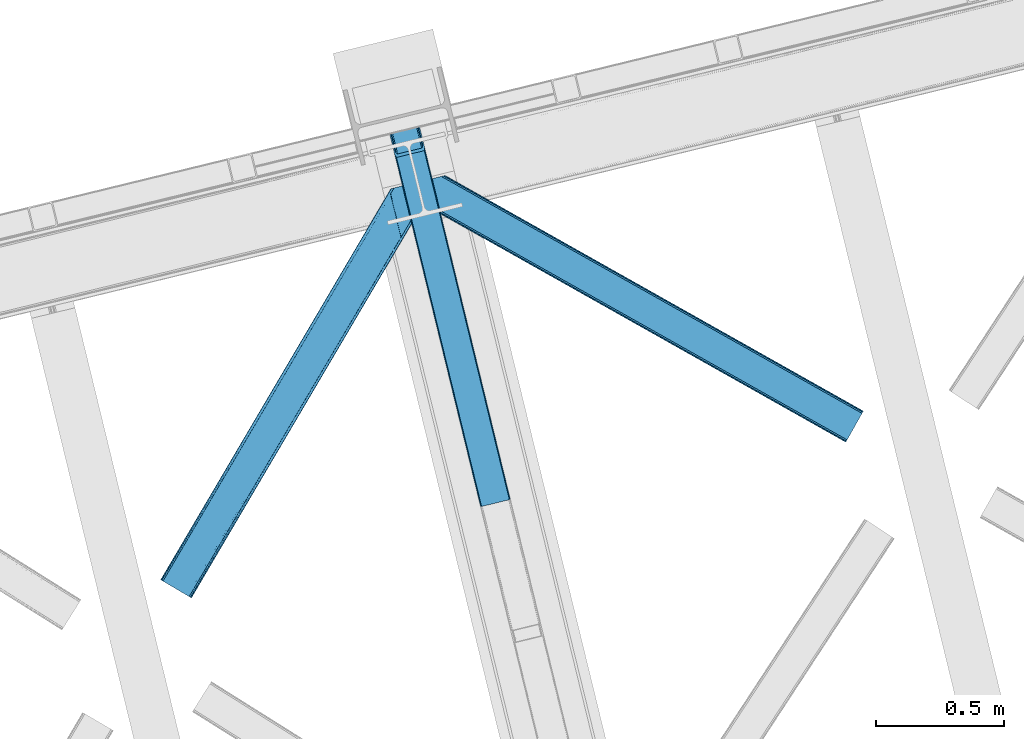
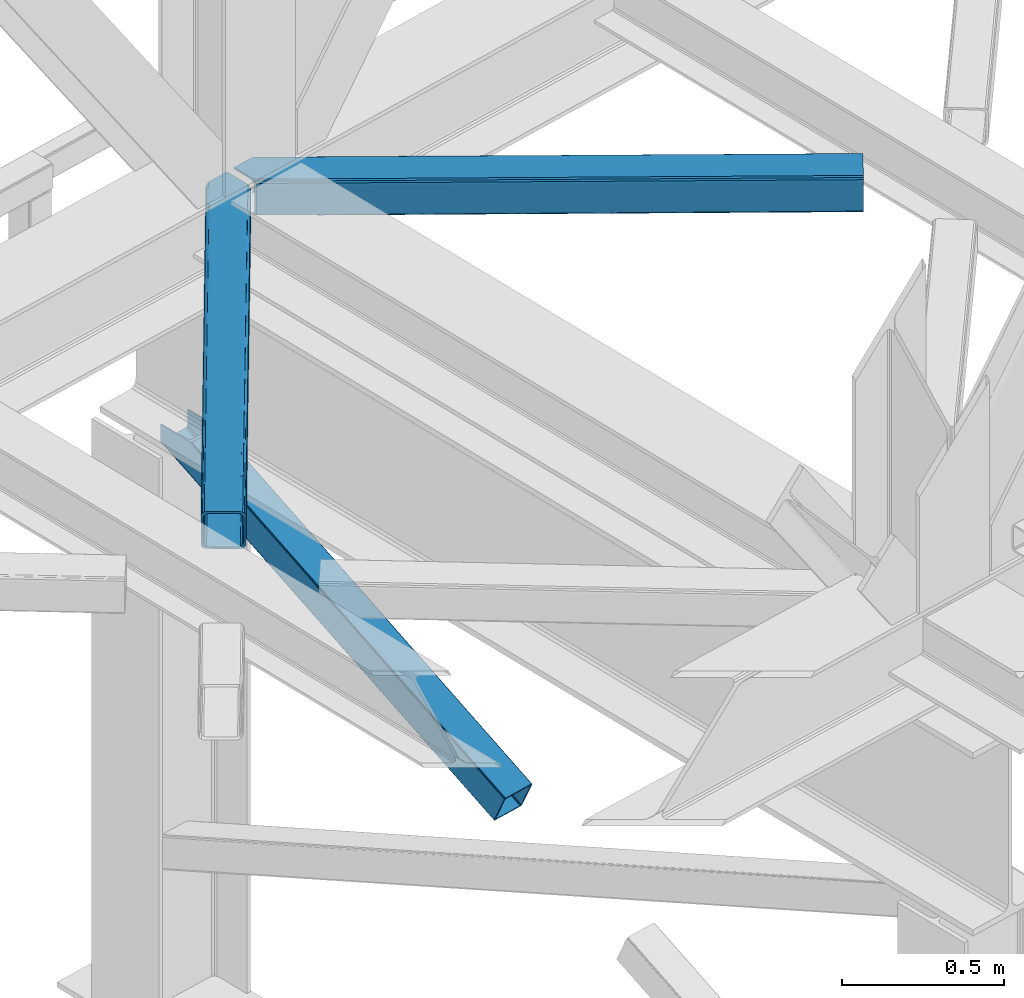
# One storey, part 40 of 92: 3 members.
"""IFC4 building model written with IfcOpenShell, lengths in millimetres."""

from ifc_helpers import new_model, entity, si_unit, converted_unit, derived_unit, direction, frame, origin, place, context, subcontext, project, spatial, triangles, type_object, element, save


model = new_model("IFC4")

# Units and contexts
model_context = context("Model", 3, precision=0.01, world=origin(), true_north=direction((6.12303176911189e-17, 1.0)))
plan_context = context("Plan", 3, precision=0.01, world=origin(), true_north=direction((6.12303176911189e-17, 1.0)))
body_context = subcontext(model_context, "Body", "Model", "MODEL_VIEW")
ifc_project = project(units=[si_unit("LENGTHUNIT", "METRE", prefix="MILLI"), si_unit("AREAUNIT", "SQUARE_METRE"), si_unit("VOLUMEUNIT", "CUBIC_METRE"), converted_unit("PLANEANGLEUNIT", "DEGREE", entity("IfcRatioMeasure", 0.0174532925199433), si_unit("PLANEANGLEUNIT", "RADIAN"), dimensions=[0, 0, 0, 0, 0, 0, 0]), si_unit("MASSUNIT", "GRAM", prefix="KILO"), derived_unit("MASSDENSITYUNIT", [(si_unit("MASSUNIT", "GRAM", prefix="KILO"), 1), (si_unit("LENGTHUNIT", "METRE"), -3)]), derived_unit("MOMENTOFINERTIAUNIT", [(si_unit("LENGTHUNIT", "METRE"), 4)]), si_unit("TIMEUNIT", "SECOND"), si_unit("FREQUENCYUNIT", "HERTZ"), si_unit("THERMODYNAMICTEMPERATUREUNIT", "DEGREE_CELSIUS"), derived_unit("THERMALTRANSMITTANCEUNIT", [(si_unit("MASSUNIT", "GRAM", prefix="KILO"), 1), (si_unit("THERMODYNAMICTEMPERATUREUNIT", "KELVIN"), -1), (si_unit("TIMEUNIT", "SECOND"), -3)]), derived_unit("VOLUMETRICFLOWRATEUNIT", [(si_unit("LENGTHUNIT", "METRE"), 3), (si_unit("TIMEUNIT", "SECOND"), -1)]), derived_unit("MASSFLOWRATEUNIT", [(si_unit("MASSUNIT", "GRAM", prefix="KILO"), 1), (si_unit("TIMEUNIT", "SECOND"), -1)]), derived_unit("ROTATIONALFREQUENCYUNIT", [(si_unit("TIMEUNIT", "SECOND"), -1)]), si_unit("ELECTRICCURRENTUNIT", "AMPERE"), si_unit("ELECTRICVOLTAGEUNIT", "VOLT"), si_unit("POWERUNIT", "WATT"), si_unit("FORCEUNIT", "NEWTON", prefix="KILO"), si_unit("ILLUMINANCEUNIT", "LUX"), si_unit("LUMINOUSFLUXUNIT", "LUMEN"), si_unit("LUMINOUSINTENSITYUNIT", "CANDELA"), derived_unit("USERDEFINED", [(si_unit("MASSUNIT", "GRAM", prefix="KILO"), -1), (si_unit("LENGTHUNIT", "METRE"), -2), (si_unit("TIMEUNIT", "SECOND"), 3), (si_unit("LUMINOUSFLUXUNIT", "LUMEN"), 1)]), derived_unit("LINEARVELOCITYUNIT", [(si_unit("LENGTHUNIT", "METRE"), 1), (si_unit("TIMEUNIT", "SECOND"), -1)]), si_unit("PRESSUREUNIT", "PASCAL"), derived_unit("USERDEFINED", [(si_unit("LENGTHUNIT", "METRE"), -2), (si_unit("MASSUNIT", "GRAM", prefix="KILO"), 1), (si_unit("TIMEUNIT", "SECOND"), -2)]), derived_unit("LINEARFORCEUNIT", [(si_unit("MASSUNIT", "GRAM", prefix="KILO"), 1), (si_unit("LENGTHUNIT", "METRE"), 1), (si_unit("TIMEUNIT", "SECOND"), -2), (si_unit("LENGTHUNIT", "METRE"), -1)]), derived_unit("PLANARFORCEUNIT", [(si_unit("MASSUNIT", "GRAM", prefix="KILO"), 1), (si_unit("LENGTHUNIT", "METRE"), 1), (si_unit("TIMEUNIT", "SECOND"), -2), (si_unit("LENGTHUNIT", "METRE"), -2)])], contexts=[model_context, plan_context])

# Site, building, storey
site_placement = place(None, origin())
site = spatial("IfcSite", under=ifc_project, at=site_placement, CompositionType="ELEMENT")
building_placement = place(site_placement, origin())
building = spatial("IfcBuilding", under=site, at=building_placement, CompositionType="ELEMENT")
storey_placement = place(building_placement, frame((0.0, 0.0, 15900.0)))
storey = spatial("IfcBuildingStorey", under=building, at=storey_placement, Name="05", CompositionType="ELEMENT", Elevation=15900.0)

# Members
member_type_1 = type_object("IfcMemberType", PredefinedType="BRACE")
member_1_placement = place(storey_placement, frame((-49464.95, 7483.37, 1850.35)))
element("IfcMember", 1, at=member_1_placement, inside=storey, type_object=member_type_1, ObjectType="Steel Vertical Brace", PredefinedType="BRACE", context=body_context, shape_type="Tessellation", body=[
    triangles([(109.783996582031, 1519.24680175781, 671.707836914062), (462.204345703125, 73.4908630371092, 0.0), (359.21993408203, 48.3871627807621, 0.0), (6.79958496093604, 1494.14310150146, 671.707836914062), (464.855346679688, 73.9117675781254, 0.48601684570167), (467.213342285155, 73.843167114258, 1.86965332031104), (112.188500976561, 1519.8328125, 672.832186889649), (468.906262207034, 73.2949447631836, 3.93929443359229), (114.593005371091, 1520.41940460205, 673.956536865233), (469.682958984376, 72.3502349853516, 6.38100585937354), (115.588293457033, 1520.66183166504, 676.672650146484), (116.583581542967, 1520.90484008789, 679.387600708007), (353.099377441409, 43.9310394287113, 6.38100585937354), (0.0, 1492.48564453125, 679.387600708007), (0.99528808593459, 1492.72807159424, 676.672650146484), (353.355175781253, 45.128059387207, 3.93929443359229), (1.99057617187646, 1492.97108001709, 673.956536865233), (354.606262207031, 46.3954238891602, 1.86965332031104), (4.39508056640625, 1493.55767211914, 672.832186889649), (356.666601562501, 47.5395401000978, 0.48601684570167), (144.93533935547, 1404.59159088135, 741.646591186523), (116.583581542967, 1520.90484008789, 741.646591186523), (480.012561035153, 29.9807281494141, 102.993713378906), (28.3517578125029, 1376.17239532471, 741.646591186523), (0.0, 1492.48564453125, 741.646591186523), (363.428979492186, 1.5615325927738, 102.993713378906), (476.445336914061, 26.3722274780275, 108.888702392578), (144.460949707034, 1388.29607391357, 741.646591186523), (142.168066406251, 1386.40316619873, 741.646591186523), (473.896655273435, 25.5251861572269, 109.37471923828), (478.505676269531, 27.5169250488279, 107.505065917969), (145.795751953126, 1392.41733398437, 741.646591186523), (479.75676269531, 28.7837081909183, 105.435424804688), (145.963183593747, 1398.13907775879, 741.646591186523), (39.1790039062471, 1361.29946594238, 741.646591186523), (370.907592773438, 0.421485900878906, 109.37471923828), (364.205676269528, 0.61682281494177, 105.435424804688), (30.4120971679658, 1369.97219238281, 741.646591186523), (365.90324707031, 0.0686004638673694, 107.505065917969), (33.1933227539048, 1364.96900939941, 741.646591186523), (368.256591796875, 0.0, 108.888702392578), (36.2722045898408, 1361.92384643555, 741.646591186523), (138.056689453122, 1403.03994140625, 741.646591186523), (137.200927734375, 1415.21477966309, 741.646591186523), (111.728063964845, 1519.72061004639, 741.646591186523), (138.22412109375, 1408.76284790039, 741.646591186523), (136.726538085939, 1398.91926269531, 741.646591186523), (134.429003906247, 1397.02635498047, 741.646591186523), (35.169946289061, 1377.96065826416, 741.646591186523), (32.3887207031221, 1382.96384124756, 741.646591186523), (30.333032226561, 1389.16346282959, 741.646591186523), (4.85551757812209, 1493.66987457275, 741.646591186523), (38.2534790039063, 1374.91549530029, 741.646591186523), (41.1602783203125, 1374.29111480713, 741.646591186523), (474.668701171875, 30.7952133178715, 98.4370147705085), (474.412902832031, 29.5981933593748, 100.87872619629), (473.157165527344, 28.3308288574217, 102.948367309571), (471.101477050783, 27.186712646484, 104.330841064453), (468.548144531247, 26.3390899658207, 104.816857910155), (375.279418945313, 3.60384979248011, 104.816857910155), (372.62841796875, 3.18294525146484, 104.330841064453), (370.270422363283, 3.25154571533221, 102.948367309571), (368.577502441403, 3.79976806640661, 100.87872619629), (367.796154785159, 4.74447784423865, 98.4370147705085), (111.728063964845, 1519.72061004639, 684.873312377931), (465.315783691403, 69.1678710937504, 10.9377044677749), (4.85551757812209, 1493.66987457275, 684.873312377931), (358.443237304688, 43.1165542602539, 10.9377044677749), (462.84151611328, 70.6602218627932, 6.42635192871239), (464.534436035159, 70.1125808715824, 8.49599304199364), (460.483520507813, 70.7294036865233, 5.04387817382667), (457.83251953125, 70.3079177856443, 4.557861328125), (359.954772949219, 45.5809387207028, 6.42635192871239), (362.01046142578, 46.7256362915041, 5.04387817382667), (358.699035644531, 44.3135742187496, 8.49599304199364), (364.563793945315, 47.5726776123047, 4.557861328125), (11.6551025390654, 1495.32733154297, 677.193548583986), (9.25059814452834, 1494.74132080078, 678.31789855957), (6.84609374999854, 1494.15531005859, 679.443411254884), (104.923828125, 1518.06257171631, 677.193548583986), (107.332983398439, 1518.64916381836, 678.31789855957), (109.73283691406, 1519.23517456055, 679.443411254884), (5.85080566406396, 1493.91288299561, 682.158361816408), (110.732775878903, 1519.47760162354, 682.158361816408)], [[1, 2, 3], [3, 4, 1], [5, 2, 1], [6, 5, 7], [8, 6, 9], [10, 8, 11], [11, 12, 10], [9, 11, 8], [7, 9, 6], [1, 7, 5], [13, 14, 15], [16, 15, 17], [18, 17, 19], [20, 19, 4], [4, 3, 20], [19, 20, 18], [17, 18, 16], [15, 16, 13], [12, 21, 10], [21, 12, 22], [23, 10, 21], [24, 14, 13], [24, 25, 14], [13, 26, 24], [27, 28, 29], [29, 30, 27], [31, 32, 28], [28, 27, 31], [33, 34, 32], [32, 31, 33], [23, 21, 34], [34, 33, 23], [30, 29, 35], [35, 36, 30], [37, 38, 26], [24, 26, 38], [39, 40, 37], [38, 37, 40], [41, 42, 39], [40, 39, 42], [36, 35, 41], [42, 41, 35], [43, 34, 21], [22, 44, 21], [44, 22, 45], [44, 46, 21], [46, 43, 21], [47, 34, 43], [32, 29, 28], [32, 34, 47], [32, 48, 29], [29, 48, 35], [47, 48, 32], [24, 38, 49], [49, 50, 24], [50, 51, 24], [51, 25, 24], [52, 25, 51], [38, 53, 49], [54, 40, 35], [54, 35, 48], [54, 53, 40], [35, 40, 42], [53, 38, 40], [44, 55, 46], [56, 46, 55], [46, 56, 43], [57, 43, 56], [43, 57, 47], [58, 47, 57], [47, 58, 48], [59, 48, 58], [48, 59, 54], [60, 54, 59], [54, 60, 61], [61, 53, 54], [53, 61, 62], [62, 49, 53], [49, 62, 63], [63, 50, 49], [50, 63, 64], [64, 51, 50], [44, 65, 66], [44, 45, 65], [66, 55, 44], [67, 51, 68], [51, 67, 52], [64, 68, 51], [55, 23, 56], [57, 33, 31], [31, 27, 57], [23, 55, 10], [23, 33, 57], [57, 56, 23], [59, 30, 36], [30, 58, 57], [59, 58, 30], [30, 57, 27], [6, 69, 5], [66, 10, 55], [69, 8, 10], [70, 10, 66], [8, 69, 6], [69, 2, 5], [10, 70, 69], [69, 71, 2], [2, 72, 3], [72, 2, 71], [62, 26, 63], [36, 60, 59], [61, 36, 62], [36, 61, 60], [62, 36, 41], [64, 63, 26], [41, 39, 62], [37, 62, 39], [64, 26, 13], [37, 26, 62], [73, 20, 3], [74, 73, 3], [75, 13, 73], [76, 3, 72], [3, 76, 74], [18, 20, 73], [13, 68, 64], [16, 73, 13], [68, 13, 75], [73, 16, 18], [77, 1, 4], [4, 19, 78], [19, 17, 15], [19, 79, 78], [4, 78, 77], [79, 19, 15], [80, 1, 77], [9, 7, 11], [7, 1, 81], [81, 82, 7], [7, 82, 11], [80, 81, 1], [11, 82, 12], [83, 14, 67], [15, 14, 79], [83, 79, 14], [25, 67, 14], [25, 52, 67], [12, 84, 65], [84, 12, 82], [65, 22, 12], [22, 65, 45], [72, 80, 76], [77, 76, 80], [66, 65, 84], [70, 84, 82], [69, 82, 81], [71, 81, 80], [80, 72, 71], [81, 71, 69], [82, 69, 70], [84, 70, 66], [74, 76, 77], [73, 74, 78], [75, 73, 79], [68, 75, 83], [83, 67, 68], [79, 83, 75], [78, 79, 73], [77, 78, 74]]),
])
member_type_2 = type_object("IfcMemberType", PredefinedType="BRACE")
member_2_placement = place(storey_placement, frame((-49332.88, 7733.55, 3511.0)))
element("IfcMember", 2, at=member_2_placement, inside=storey, type_object=member_type_2, ObjectType="Steel Horizontal Brace", PredefinedType="BRACE", context=body_context, shape_type="Tessellation", body=[
    triangles([(1656.08961181641, 0.0, 122.500662231447), (1656.74538574219, 1.16039428710974, 129.197927856447), (23.8915649414048, 919.17296447754, 122.500662231447), (23.4590332031294, 920.94494934082, 129.197927856447), (1658.60573730469, 4.46600646972638, 134.874325561526), (22.2265502929731, 925.991734313965, 134.874325561526), (1661.39161376953, 9.41279754638708, 138.667117309571), (20.3894531250044, 933.544180297852, 138.667117309571), (1664.67513427734, 15.2484878540045, 139.999594116212), (18.2174926757798, 942.452938842774, 139.999594116212), (1656.08961181641, 0.0, 17.5000946044929), (23.8915649414048, 919.17296447754, 17.5000946044929), (1716.19757080078, 106.738252258301, 139.999594116212), (69.4469238281235, 1034.10722808838, 139.999594116212), (0.0, 1017.17919158936, 139.999594116212), (1719.4857421875, 112.573361206055, 138.667117309571), (78.971923828125, 1036.42917938232, 138.667117309571), (1722.27161865235, 117.520152282715, 134.874325561526), (87.0458496093779, 1038.39766387939, 134.874325561526), (1724.13197021485, 120.825764465332, 129.197927856447), (92.4408691406279, 1039.71269989014, 129.197927856447), (1724.78774414062, 121.986740112305, 122.500662231447), (94.3384277343794, 1040.17488098145, 122.500662231447), (1724.78774414062, 121.986740112305, 17.5000946044929), (94.3384277343794, 1040.17488098145, 17.5000946044929), (1656.74538574219, 1.16039428710974, 10.8028289794929), (1658.60573730469, 4.46600646972638, 5.12526855468968), (196.057800292969, 824.821165466309, 8.8831787109375), (196.076403808598, 825.066499328613, 8.50064392089917), (23.3706665039063, 921.307136535645, 10.8691040039084), (195.062512207034, 824.99848022461, 9.50058288574292), (195.732238769531, 824.878720092774, 9.08316650390771), (23.263696289061, 921.747807312012, 9.50058288574292), (195.220642089844, 828.57035522461, 5.12526855468968), (1664.67513427734, 15.2484878540045, 0.0), (1661.39161376953, 9.41279754638708, 1.33247680664135), (193.378894042973, 836.122801208497, 1.33247680664135), (191.206933593749, 845.031559753418, 0.0), (1716.19757080078, 106.738252258301, 0.0), (157.162499999999, 984.71082458496, 0.0), (191.346459960936, 843.22294921875, 9.20757751465135), (191.290649414063, 844.06824645996, 8.85411071777344), (191.104614257813, 845.460603332519, 8.41343994140698), (18.8686157226548, 939.774032592774, 9.50058288574292), (1724.13197021485, 120.825764465332, 10.8028289794929), (92.0548461914077, 1039.61851959229, 10.8702667236357), (150.921020507813, 1006.08800811768, 9.50058288574292), (1722.27161865235, 117.520152282715, 5.12526855468968), (153.148791503911, 1001.17202911377, 5.12526855468968), (152.293029785156, 1004.67588500977, 8.50064392089917), (151.60469970703, 1005.38223724365, 9.00061340332104), (91.5851074218735, 1039.50341033936, 9.50058288574292), (1719.4857421875, 112.573361206055, 1.33247680664135), (154.990539550781, 993.619583129884, 1.33247680664135), (156.250927734378, 986.702563476562, 9.11688537597729), (155.813745117186, 987.634483337403, 9.42384338378906), (156.692761230472, 985.76134185791, 8.80760192871094), (157.129943847656, 984.828840637208, 8.50064392089917), (155.316101074219, 988.061782836915, 9.50058288574292), (72.3118652343765, 1034.80544128418, 9.50058288574292), (159.43212890625, 975.399183654786, 6.99957275390625), (188.937304687504, 854.343782043456, 6.99957275390625), (1668.11213378907, 21.3475341796875, 6.99957275390625), (1712.76522216797, 100.639205932617, 6.99957275390625), (19.9569213867217, 935.303375244142, 12.1260040283232), (1662.0380859375, 10.5650527954103, 12.1260040283232), (1664.82396240235, 15.5124252319338, 8.3320495605476), (1659.52661132813, 6.09904632568396, 24.4996673583992), (1660.177734375, 7.26002197265643, 17.8035644531265), (21.6219360351606, 928.485186767578, 24.4996673583992), (21.1894042968779, 930.25717163086, 17.8035644531265), (1716.04874267578, 106.474314880371, 8.3320495605476), (1718.83927001953, 111.421105957032, 12.1260040283232), (77.0929687500029, 1035.9704864502, 12.1260040283232), (1720.69962158203, 114.726718139648, 17.8035644531265), (82.4879882812529, 1037.2861038208, 17.8035644531265), (1721.35074462891, 115.887112426758, 24.4996673583992), (84.3808959960952, 1037.74770355225, 24.4996673583992), (1659.52661132813, 6.09904632568396, 115.501089477541), (21.6219360351606, 928.485186767578, 115.501089477541), (21.1894042968779, 930.25717163086, 122.196029663086), (19.9569213867217, 935.303375244142, 127.87475280762), (15.9478637695356, 951.765161132812, 133.000021362306), (18.1198242187529, 942.855821228027, 131.667544555665), (0.0, 1017.17919158936, 133.000021362306), (1668.11213378907, 21.3475341796875, 133.000021362306), (1664.82396240235, 15.5124252319338, 131.667544555665), (1662.0380859375, 10.5650527954103, 127.87475280762), (1660.177734375, 7.26002197265643, 122.196029663086), (1718.83927001953, 111.421105957032, 127.87475280762), (1720.69962158203, 114.726718139648, 122.196029663086), (1721.35074462891, 115.887112426758, 115.501089477541), (1712.76522216797, 100.639205932617, 133.000021362306), (1716.04874267578, 106.474314880371, 131.667544555665), (77.0929687500029, 1035.9704864502, 127.87475280762), (69.0143920898481, 1034.00200195312, 131.667544555665), (82.4879882812529, 1037.2861038208, 122.196029663086), (59.4893920898467, 1031.68005065918, 133.000021362306), (84.3808959960952, 1037.74770355225, 115.501089477541)], [[1, 2, 3], [4, 3, 2], [2, 5, 4], [6, 4, 5], [5, 7, 6], [8, 6, 7], [7, 9, 8], [10, 8, 9], [11, 1, 12], [3, 12, 1], [13, 10, 9], [10, 13, 14], [15, 10, 14], [13, 16, 17], [17, 14, 13], [16, 18, 19], [19, 17, 16], [18, 20, 21], [21, 19, 18], [20, 22, 23], [23, 21, 20], [22, 24, 23], [25, 23, 24], [26, 11, 12], [27, 28, 29], [26, 30, 31], [31, 27, 26], [31, 32, 27], [30, 33, 31], [29, 34, 27], [35, 36, 37], [37, 38, 35], [36, 27, 34], [34, 37, 36], [12, 30, 26], [39, 35, 38], [38, 40, 39], [41, 42, 29], [42, 43, 29], [41, 31, 33], [33, 44, 41], [45, 46, 25], [46, 45, 47], [45, 48, 49], [49, 50, 45], [45, 50, 51], [51, 47, 45], [47, 52, 46], [48, 53, 54], [54, 49, 48], [53, 39, 40], [40, 54, 53], [25, 24, 45], [51, 55, 56], [50, 57, 55], [50, 58, 57], [47, 59, 52], [60, 52, 59], [61, 40, 62], [54, 58, 49], [58, 54, 40], [49, 58, 50], [40, 61, 58], [62, 40, 38], [37, 43, 38], [43, 37, 34], [38, 43, 62], [34, 29, 43], [63, 64, 62], [61, 62, 64], [63, 62, 43], [41, 65, 66], [41, 44, 65], [43, 66, 67], [66, 43, 42], [42, 41, 66], [43, 67, 63], [68, 69, 70], [71, 70, 69], [69, 66, 71], [65, 71, 66], [72, 58, 61], [57, 72, 55], [57, 58, 72], [56, 55, 72], [73, 74, 59], [59, 72, 73], [74, 60, 59], [73, 75, 76], [76, 74, 73], [75, 77, 78], [78, 76, 75], [61, 64, 72], [79, 68, 80], [70, 80, 68], [81, 6, 82], [80, 70, 3], [4, 81, 3], [81, 4, 6], [81, 80, 3], [70, 12, 3], [71, 65, 33], [33, 30, 71], [30, 12, 71], [70, 71, 12], [83, 10, 15], [10, 84, 8], [84, 10, 83], [15, 85, 83], [84, 82, 8], [44, 33, 65], [8, 82, 6], [86, 87, 84], [84, 83, 86], [87, 88, 82], [82, 84, 87], [88, 89, 81], [81, 82, 88], [89, 79, 80], [80, 81, 89], [20, 90, 91], [92, 24, 22], [20, 91, 22], [20, 18, 90], [91, 92, 22], [90, 18, 16], [93, 13, 9], [13, 94, 16], [94, 13, 93], [94, 90, 16], [45, 73, 48], [77, 24, 92], [24, 75, 45], [75, 24, 77], [45, 75, 73], [39, 64, 35], [53, 48, 73], [73, 72, 53], [72, 64, 39], [39, 53, 72], [88, 7, 5], [9, 86, 93], [9, 87, 86], [87, 9, 7], [88, 87, 7], [79, 1, 11], [2, 89, 88], [5, 2, 88], [89, 2, 1], [79, 89, 1], [36, 66, 27], [35, 64, 63], [63, 67, 35], [67, 66, 36], [36, 35, 67], [26, 27, 66], [11, 68, 79], [69, 11, 26], [11, 69, 68], [69, 26, 66], [95, 96, 17], [19, 95, 17], [19, 21, 97], [95, 19, 97], [97, 21, 23], [96, 14, 17], [15, 98, 85], [15, 14, 98], [96, 98, 14], [97, 23, 99], [78, 25, 76], [23, 78, 99], [25, 46, 76], [23, 25, 78], [52, 76, 46], [74, 76, 52], [60, 74, 52], [93, 83, 98], [93, 86, 83], [83, 85, 98], [77, 92, 99], [99, 78, 77], [92, 91, 99], [97, 99, 91], [91, 90, 97], [95, 97, 90], [90, 94, 95], [96, 95, 94], [94, 93, 96], [98, 96, 93]]),
])
member_type_3 = type_object("IfcMemberType", PredefinedType="BRACE")
member_3_placement = place(storey_placement, frame((-50348.28, 7126.42, 3511.0)))
element("IfcMember", 3, at=member_3_placement, inside=storey, type_object=member_type_3, ObjectType="Steel Horizontal Brace", PredefinedType="BRACE", context=body_context, shape_type="Tessellation", body=[
    triangles([(105.565649414064, 8.87852783203198, 0.0), (15.0828002929702, 62.1485321044929, 0.0), (892.847827148435, 1346.13992614746, 0.0), (857.170935058595, 1492.50308532715, 0.0), (854.896655273435, 1501.83798065186, 1.33247680664135), (9.31105957031104, 65.5459991455082, 1.33247680664135), (852.966540527341, 1509.7520324707, 5.12526855468968), (4.4183349609375, 68.4266372680668, 5.12526855468968), (851.678247070311, 1515.03950042725, 10.8028289794929), (1.14876708984229, 70.3509384155277, 10.8028289794929), (851.222460937497, 1516.89636383057, 17.5000946044929), (0.0, 71.027059936524, 17.5000946044929), (893.638476562497, 1342.89826354981, 0.155804443362285), (111.337390136716, 5.48106079101581, 1.33247680664135), (899.559045410155, 1344.34178009033, 1.33247680664135), (912.390820312496, 1347.47007751465, 10.8028289794929), (914.195361328122, 1347.90958557129, 17.5000946044929), (120.643798828125, 0.0, 17.5000946044929), (119.499682617185, 0.676121520996276, 10.8028289794929), (907.251599121089, 1346.21724700928, 5.12526855468968), (116.230114746089, 2.60042266845721, 5.12526855468968), (902.498400878903, 1345.05743408203, 17.9802978515654), (893.638476562497, 1342.89826354981, 9.69243164062573), (897.768457031249, 1343.90517883301, 12.1260040283232), (903.726232910158, 1345.35683441162, 19.4999725341804), (914.195361328122, 1347.90958557129, 19.4999725341804), (1011.61732177734, 1513.38669433594, 19.4999725341804), (1008.98957519531, 1524.16103668213, 19.4999725341804), (1011.61732177734, 1513.38669433594, 122.500662231447), (120.643798828125, 0.0, 122.500662231447), (114.61160888672, 3.5515274047857, 24.4996673583992), (1009.24072265625, 1523.14423828125, 24.4996673583992), (113.462841796871, 4.22706756591833, 17.8035644531265), (110.197924804685, 6.15195007324292, 12.1260040283232), (105.305200195311, 9.03200683593786, 8.3320495605476), (99.5334594726519, 12.4294738769531, 6.99957275390625), (892.685046386716, 1346.80035095215, 8.88434143066479), (890.471228027345, 1355.89747009277, 6.99957275390625), (21.114990234375, 58.5975860595709, 6.99957275390625), (859.547534179685, 1482.74496002197, 6.99957275390625), (853.961828613283, 1505.66042175293, 18.5000335693367), (851.222460937497, 1516.89636383057, 18.5000335693367), (854.096704101561, 1505.10929260254, 17.8803039550803), (855.343139648438, 1499.99448852539, 12.1260040283232), (857.273254394531, 1492.08043670654, 8.3320495605476), (1009.24072265625, 1523.14423828125, 115.501089477541), (114.61160888672, 3.5515274047857, 115.501089477541), (1008.78493652344, 1525.00110168457, 122.196029663086), (113.462841796871, 4.22706756591833, 122.196029663086), (1007.49664306641, 1530.28915100098, 127.87475280762), (110.197924804685, 6.15195007324292, 127.87475280762), (1005.57117919921, 1538.20320281983, 131.667544555665), (105.305200195311, 9.03200683593786, 131.667544555665), (1003.29224853515, 1547.53809814453, 133.000021362306), (99.5334594726519, 12.4294738769531, 133.000021362306), (851.952648925777, 1518.13291625977, 19.4999725341804), (854.580395507808, 1507.35857391358, 19.4999725341804), (851.780566406247, 1517.84049224854, 19.2639404296897), (854.43156738281, 1506.95045928955, 19.2592895507842), (851.589880371095, 1517.5149307251, 19.0000030517585), (854.268786621091, 1506.50978851318, 19.0000030517585), (851.394543457027, 1517.1887878418, 18.736065673831), (854.110656738281, 1506.06853637695, 18.7407165527366), (908.014343261719, 1598.12687072754, 19.4999725341804), (897.545214843747, 1595.57411956787, 19.4999725341804), (1011.16618652343, 1515.24355773926, 129.197927856447), (1009.8778930664, 1520.53160705566, 134.874325561526), (1008.43146972656, 1526.45624542236, 137.999716186525), (986.311889648438, 1617.21175231934, 137.999716186525), (986.311889648438, 1617.21175231934, 133.000021362306), (897.545214843747, 1595.57411956787, 122.500662231447), (0.0, 71.027059936524, 122.500662231447), (7.18095703124709, 66.7999923706057, 17.8035644531265), (10.4505249023423, 64.875109863282, 12.1260040283232), (6.03218994140479, 67.4755325317383, 24.4996673583992), (907.028356933595, 1597.88560638428, 24.4996673583992), (15.3432495117158, 61.9950531005861, 8.3320495605476), (908.832897949214, 1598.32569580078, 122.196029663086), (899.349755859374, 1596.01362762451, 129.197927856447), (904.48897705078, 1597.26645812988, 134.874325561526), (930.738537597652, 1603.66548614502, 133.000021362306), (910.246765136719, 1598.67044219971, 137.999716186525), (921.664672851563, 1601.45341186523, 131.667544555665), (913.972119140621, 1599.57852630615, 127.87475280762), (907.028356933595, 1597.88560638428, 115.501089477541), (21.114990234375, 58.5975860595709, 133.000021362306), (6.03218994140479, 67.4755325317383, 115.501089477541), (15.3432495117158, 61.9950531005861, 131.667544555665), (10.4505249023423, 64.875109863282, 127.87475280762), (7.18095703124709, 66.7999923706057, 122.196029663086), (119.499682617185, 0.676121520996276, 129.197927856447), (116.230114746089, 2.60042266845721, 134.874325561526), (111.337390136716, 5.48106079101581, 138.667117309571), (105.565649414064, 8.87852783203198, 139.999594116212), (15.0828002929702, 62.1485321044929, 139.999594116212), (9.31105957031104, 65.5459991455082, 138.667117309571), (4.4183349609375, 68.4266372680668, 134.874325561526), (1.14876708984229, 70.3509384155277, 129.197927856447), (896.991760253906, 1576.15611877441, 137.999716186525), (938.18924560547, 1407.14434204102, 137.999716186525), (899.024194335936, 1563.59525756836, 139.999594116212), (897.042919921871, 1571.7232498169, 138.999655151369), (896.801074218747, 1573.1371170044, 138.639212036134), (896.926647949214, 1575.15443572998, 138.211331176761), (896.86153564453, 1574.14170684815, 138.427597045898), (937.477661132813, 1407.08620605469, 138.29272155762), (937.082336425781, 1408.09544677734, 138.646188354494), (936.682360839841, 1409.1046875, 138.999655151369), (934.701086425783, 1417.23267974854, 139.999594116212)], [[1, 2, 3], [4, 3, 2], [5, 4, 6], [2, 6, 4], [7, 5, 8], [6, 8, 5], [9, 7, 10], [8, 10, 7], [11, 9, 12], [10, 12, 9], [1, 3, 13], [13, 14, 1], [13, 15, 14], [16, 17, 18], [18, 19, 16], [20, 16, 19], [19, 21, 20], [15, 20, 21], [21, 14, 15], [20, 22, 16], [23, 24, 15], [23, 15, 13], [15, 24, 20], [16, 25, 17], [20, 24, 22], [16, 22, 25], [26, 17, 25], [26, 25, 27], [28, 27, 25], [27, 29, 26], [30, 26, 29], [26, 18, 17], [30, 18, 26], [31, 32, 25], [25, 33, 31], [25, 22, 33], [32, 28, 25], [33, 22, 24], [34, 24, 23], [23, 35, 34], [36, 35, 37], [37, 38, 36], [23, 37, 35], [24, 34, 33], [39, 36, 38], [38, 40, 39], [9, 11, 41], [11, 42, 41], [43, 9, 41], [43, 7, 9], [44, 7, 43], [5, 44, 45], [44, 5, 7], [4, 5, 45], [45, 40, 4], [37, 23, 13], [37, 3, 38], [3, 40, 38], [40, 3, 4], [37, 13, 3], [46, 32, 31], [31, 47, 46], [48, 46, 49], [47, 49, 46], [50, 48, 51], [49, 51, 48], [52, 50, 53], [51, 53, 50], [54, 52, 55], [53, 55, 52], [56, 57, 58], [59, 58, 57], [58, 59, 60], [61, 60, 59], [60, 61, 62], [63, 62, 61], [62, 63, 42], [41, 42, 63], [57, 56, 64], [65, 64, 56], [66, 48, 67], [46, 29, 27], [27, 32, 46], [32, 27, 28], [48, 29, 46], [66, 29, 48], [50, 68, 67], [52, 68, 50], [67, 48, 50], [52, 54, 68], [54, 69, 68], [70, 69, 54], [71, 60, 62], [58, 60, 71], [71, 56, 58], [56, 71, 65], [42, 12, 72], [12, 42, 11], [71, 42, 72], [42, 71, 62], [73, 74, 44], [75, 73, 43], [43, 41, 75], [43, 57, 75], [64, 76, 57], [75, 57, 76], [44, 43, 73], [45, 44, 74], [74, 77, 45], [40, 45, 77], [77, 39, 40], [78, 79, 80], [81, 82, 69], [69, 70, 81], [81, 83, 82], [84, 82, 83], [80, 82, 84], [78, 71, 79], [85, 71, 78], [80, 84, 78], [65, 76, 64], [85, 65, 71], [76, 65, 85], [86, 54, 55], [54, 86, 81], [70, 54, 81], [76, 85, 87], [87, 75, 76], [83, 81, 86], [86, 88, 83], [84, 83, 88], [88, 89, 84], [78, 84, 89], [89, 90, 78], [85, 78, 90], [90, 87, 85], [91, 51, 49], [47, 18, 30], [91, 49, 30], [91, 92, 51], [49, 47, 30], [51, 92, 93], [55, 94, 95], [94, 53, 93], [53, 94, 55], [53, 51, 93], [19, 34, 21], [31, 18, 47], [18, 33, 19], [33, 18, 31], [19, 33, 34], [1, 36, 2], [14, 21, 34], [34, 35, 14], [35, 36, 1], [1, 14, 35], [89, 96, 97], [95, 86, 55], [95, 88, 86], [88, 95, 96], [89, 88, 96], [87, 72, 12], [98, 90, 89], [97, 98, 89], [90, 98, 72], [87, 90, 72], [6, 74, 8], [2, 36, 39], [39, 77, 2], [77, 74, 6], [6, 2, 77], [10, 8, 74], [12, 75, 87], [73, 12, 10], [12, 73, 75], [73, 10, 74], [99, 68, 82], [99, 100, 68], [68, 69, 82], [96, 95, 101], [101, 102, 96], [97, 96, 103], [104, 97, 105], [104, 99, 97], [97, 103, 105], [82, 80, 99], [97, 99, 80], [102, 103, 96], [79, 71, 98], [72, 98, 71], [80, 79, 97], [98, 97, 79], [92, 67, 100], [100, 93, 92], [67, 68, 100], [106, 107, 93], [94, 93, 107], [107, 108, 94], [108, 109, 94], [66, 67, 92], [92, 91, 66], [29, 66, 91], [91, 30, 29], [95, 94, 109], [109, 101, 95], [107, 103, 102], [105, 103, 107], [106, 104, 105], [100, 99, 104], [107, 106, 105], [102, 108, 107], [102, 101, 109], [109, 108, 102]]),
])

save(model, "model.ifc")
